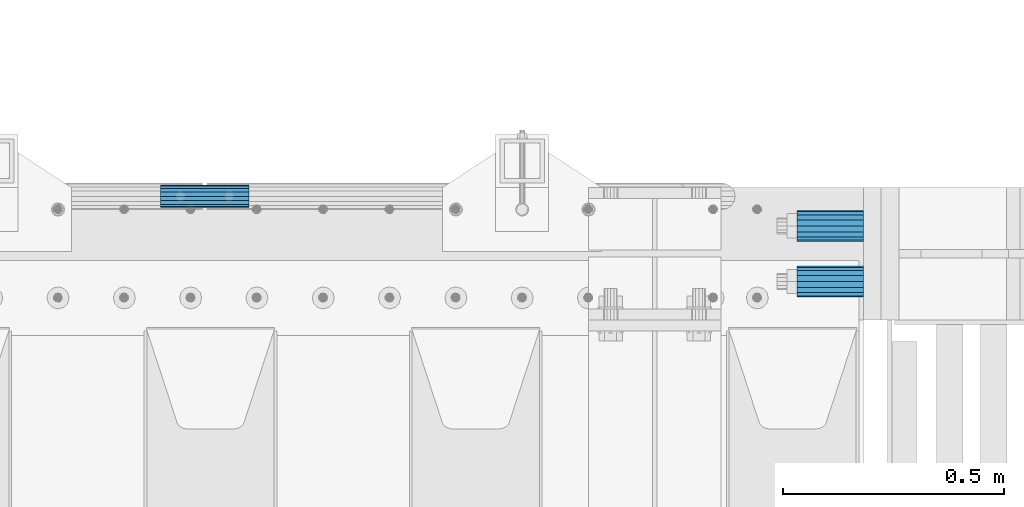
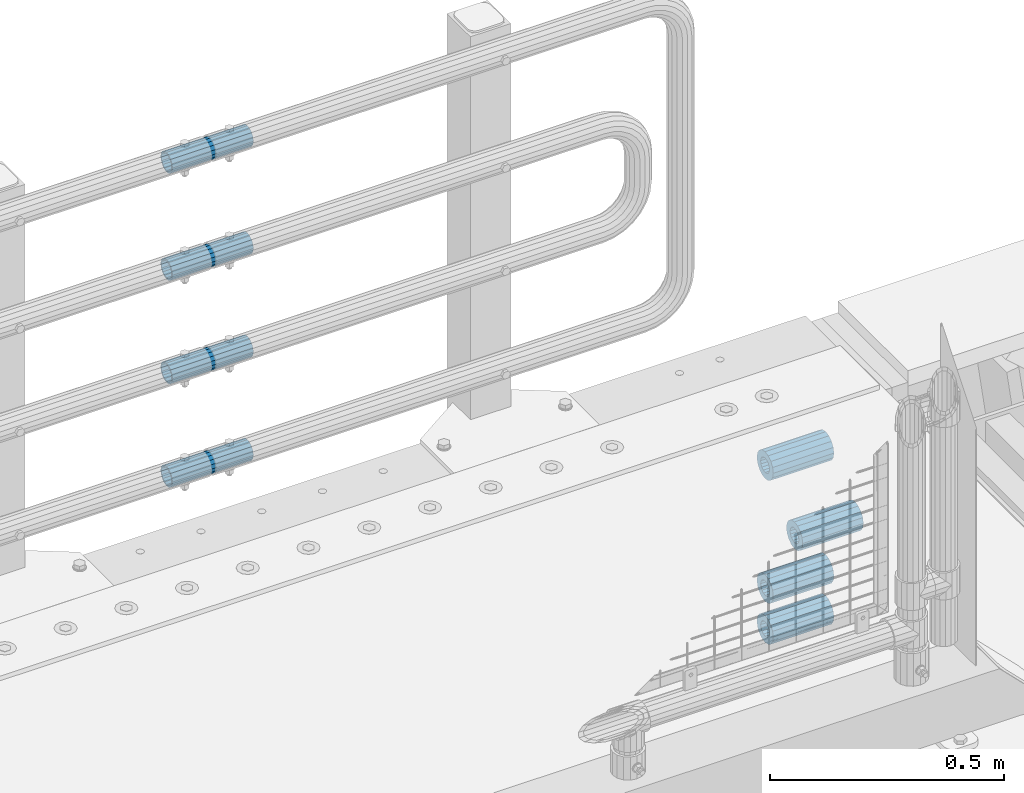
# One storey, part 166 of 240: 8 beams.
"""IFC2X3 building model written with IfcOpenShell, lengths in millimetres."""

from ifc_helpers import new_model, si_unit, frame, origin_with_axes, place, context, subcontext, project, spatial, faceted_brep, material, type_object, element, save


model = new_model("IFC2X3")

# Units and contexts
model_context = context("Model", 3, precision=1e-05, world=origin_with_axes())
body_context = subcontext(model_context, "Body", "Model", "MODEL_VIEW")
ifc_project = project(units=[si_unit("LENGTHUNIT", "METRE", prefix="MILLI"), si_unit("AREAUNIT", "SQUARE_METRE"), si_unit("VOLUMEUNIT", "CUBIC_METRE"), si_unit("MASSUNIT", "GRAM", prefix="KILO"), si_unit("TIMEUNIT", "SECOND"), si_unit("PLANEANGLEUNIT", "RADIAN"), si_unit("SOLIDANGLEUNIT", "STERADIAN"), si_unit("THERMODYNAMICTEMPERATUREUNIT", "DEGREE_CELSIUS"), si_unit("LUMINOUSINTENSITYUNIT", "LUMEN")], contexts=[model_context])

# Site, building, storey
site_placement = place(None, origin_with_axes())
site = spatial("IfcSite", under=ifc_project, at=site_placement, CompositionType="ELEMENT")
building_placement = place(site_placement, origin_with_axes())
building = spatial("IfcBuilding", under=site, at=building_placement, Name="Standard", CompositionType="ELEMENT")
storey_placement = place(building_placement, origin_with_axes())
storey = spatial("IfcBuildingStorey", under=building, at=storey_placement, Name="Undefined", CompositionType="ELEMENT", Elevation=0.0)

# Beams
ifc_material = material()
beam_type_1 = type_object("IfcBeamType", PredefinedType="NOTDEFINED")
beam_1_placement = place(storey_placement, frame((56327.0, 36063.0, -285.0), z_axis=(0.0, 0.0, 1.0), x_axis=(1.0, 0.0, 0.0)))
element("IfcBeam", 1, at=beam_1_placement, inside=storey, type_object=beam_type_1, material=ifc_material, context=body_context, shape_type="Brep", body=[
    faceted_brep([(-1.31236447487026e-07, -18.9999999995492, -6.26459950581193e-09), (0.0, -17.5537111177146, 7.27098521493673), (150.0, -17.5537111177146, 7.27098521493673), (150.0, -19.0, 0.0), (0.0, -13.4350288425449, 13.4350288425444), (150.0, -13.4350288425449, 13.4350288425444), (0.0, -7.27098521493826, 17.5537111177144), (150.0, -7.27098521493826, 17.5537111177144), (-6.35918695479631e-09, 4.50199877377599e-10, 18.9999999937281), (150.0, 0.0, 19.0), (0.0, 7.27098521493826, 17.5537111177144), (150.0, 7.27098521493826, 17.5537111177144), (0.0, 13.4350288425449, 13.4350288425444), (150.0, 13.4350288425449, 13.4350288425444), (0.0, 17.5537111177146, 7.27098521493673), (150.0, 17.5537111177146, 7.27098521493673), (1.33248249767348e-07, 19.0000000004507, -6.26459950581193e-09), (150.0, 19.0, 0.0), (0.0, 17.5537111177146, -7.27098521493673), (150.0, 17.5537111177146, -7.27098521493673), (0.0, 13.4350288425449, -13.4350288425444), (150.0, 13.4350288425449, -13.4350288425444), (0.0, 7.27098521493826, -17.5537111177144), (150.0, 7.27098521493826, -17.5537111177144), (8.37098923511803e-09, 4.50313564215321e-10, -19.0000000062646), (150.0, 0.0, -19.0), (0.0, -7.27098521493826, -17.5537111177144), (150.0, -7.27098521493826, -17.5537111177144), (0.0, -13.4350288425449, -13.4350288425444), (150.0, -13.4350288425449, -13.4350288425444), (0.0, -17.5537111177146, -7.27098521493673), (150.0, -17.5537111177146, -7.27098521493673), (0.0, -35.0, 0.0), (7.27595761418343e-12, -32.335783637895, -13.3939201327739), (150.0, -32.3357836378964, -13.3939201327782), (150.0, -35.0, 0.0), (0.0, -24.7487373415292, -24.7487373415279), (150.0, -24.7487373415279, -24.7487373415292), (7.27595761418343e-12, -13.3939201327781, -32.3357836378891), (150.0, -13.3939201327776, -32.335783637895), (7.27595761418343e-12, 0.0, -35.0), (150.0, 0.0, -35.0), (7.27595761418343e-12, 13.3939201327782, -32.3357836378891), (150.0, 13.3939201327776, -32.335783637895), (0.0, 24.7487373415292, -24.7487373415279), (150.0, 24.7487373415279, -24.7487373415291), (7.27595761418343e-12, 32.335783637895, -13.3939201327739), (150.0, 32.3357836378964, -13.3939201327781), (0.0, 35.0, 0.0), (150.0, 35.0, 0.0), (0.0, 32.335783637895, 13.3939201327812), (150.0, 32.3357836378964, 13.3939201327781), (0.0, 24.7487373415292, 24.7487373415279), (150.0, 24.7487373415279, 24.7487373415292), (0.0, 13.3939201327781, 32.3357836378964), (150.0, 13.3939201327776, 32.335783637895), (0.0, 0.0, 35.0), (150.0, 0.0, 35.0), (0.0, -13.3939201327781, 32.3357836378964), (150.0, -13.3939201327776, 32.335783637895), (0.0, -24.7487373415292, 24.7487373415279), (150.0, -24.7487373415279, 24.7487373415292), (0.0, -32.335783637895, 13.3939201327812), (150.0, -32.3357836378964, 13.3939201327781)], [[[0, 1, 2, 3]], [[1, 4, 5, 2]], [[4, 6, 7, 5]], [[6, 8, 9, 7]], [[8, 10, 11, 9]], [[10, 12, 13, 11]], [[12, 14, 15, 13]], [[14, 16, 17, 15]], [[16, 18, 19, 17]], [[18, 20, 21, 19]], [[20, 22, 23, 21]], [[22, 24, 25, 23]], [[24, 26, 27, 25]], [[26, 28, 29, 27]], [[28, 30, 31, 29]], [[30, 0, 3, 31]], [[32, 33, 34, 35]], [[33, 36, 37, 34]], [[36, 38, 39, 37]], [[38, 40, 41, 39]], [[40, 42, 43, 41]], [[42, 44, 45, 43]], [[44, 46, 47, 45]], [[46, 48, 49, 47]], [[48, 50, 51, 49]], [[50, 52, 53, 51]], [[52, 54, 55, 53]], [[54, 56, 57, 55]], [[56, 58, 59, 57]], [[58, 60, 61, 59]], [[60, 62, 63, 61]], [[62, 32, 35, 63]], [[37, 39, 41, 43, 45, 47, 49, 51, 53, 55, 57, 59, 61, 63, 35, 34], [5, 7, 9, 11, 13, 15, 17, 19, 21, 23, 25, 27, 29, 31, 3, 2]], [[62, 60, 58, 56, 54, 52, 50, 48, 46, 44, 42, 40, 38, 36, 33, 32], [30, 28, 26, 24, 22, 20, 18, 16, 14, 12, 10, 8, 6, 4, 1, 0]]]),
])
beam_2_placement = place(storey_placement, frame((56327.0, 35937.0, -392.0), z_axis=(0.0, 0.0, 1.0), x_axis=(1.0, 0.0, 0.0)))
element("IfcBeam", 2, at=beam_2_placement, inside=storey, type_object=beam_type_1, material=ifc_material, context=body_context, shape_type="Brep", body=[
    faceted_brep([(-1.31236447487026e-07, -18.9999999995492, -6.26459950581193e-09), (0.0, -17.5537111177146, 7.27098521493673), (150.0, -17.5537111177146, 7.27098521493673), (150.0, -19.0, 0.0), (0.0, -13.4350288425449, 13.4350288425444), (150.0, -13.4350288425449, 13.4350288425444), (0.0, -7.27098521493826, 17.5537111177144), (150.0, -7.27098521493826, 17.5537111177144), (-6.35918695479631e-09, 4.50199877377599e-10, 18.9999999937281), (150.0, 0.0, 19.0), (0.0, 7.27098521493826, 17.5537111177144), (150.0, 7.27098521493826, 17.5537111177144), (0.0, 13.4350288425449, 13.4350288425444), (150.0, 13.4350288425449, 13.4350288425444), (0.0, 17.5537111177146, 7.27098521493673), (150.0, 17.5537111177146, 7.27098521493673), (1.33248249767348e-07, 19.0000000004507, -6.26459950581193e-09), (150.0, 19.0, 0.0), (0.0, 17.5537111177146, -7.27098521493673), (150.0, 17.5537111177146, -7.27098521493673), (0.0, 13.4350288425449, -13.4350288425444), (150.0, 13.4350288425449, -13.4350288425444), (0.0, 7.27098521493826, -17.5537111177144), (150.0, 7.27098521493826, -17.5537111177144), (8.37098923511803e-09, 4.50313564215321e-10, -19.0000000062646), (150.0, 0.0, -19.0), (0.0, -7.27098521493826, -17.5537111177144), (150.0, -7.27098521493826, -17.5537111177144), (0.0, -13.4350288425449, -13.4350288425444), (150.0, -13.4350288425449, -13.4350288425444), (0.0, -17.5537111177146, -7.27098521493673), (150.0, -17.5537111177146, -7.27098521493673), (0.0, -35.0, 0.0), (7.27595761418343e-12, -32.335783637895, -13.3939201327739), (150.0, -32.3357836378964, -13.3939201327782), (150.0, -35.0, 0.0), (0.0, -24.7487373415292, -24.7487373415279), (150.0, -24.7487373415279, -24.7487373415292), (7.27595761418343e-12, -13.3939201327781, -32.3357836378891), (150.0, -13.3939201327776, -32.335783637895), (7.27595761418343e-12, 0.0, -35.0), (150.0, 0.0, -35.0), (7.27595761418343e-12, 13.3939201327782, -32.3357836378891), (150.0, 13.3939201327776, -32.335783637895), (0.0, 24.7487373415292, -24.7487373415279), (150.0, 24.7487373415279, -24.7487373415291), (7.27595761418343e-12, 32.335783637895, -13.3939201327739), (150.0, 32.3357836378964, -13.3939201327781), (0.0, 35.0, 0.0), (150.0, 35.0, 0.0), (0.0, 32.335783637895, 13.3939201327812), (150.0, 32.3357836378964, 13.3939201327781), (0.0, 24.7487373415292, 24.7487373415279), (150.0, 24.7487373415279, 24.7487373415292), (0.0, 13.3939201327781, 32.3357836378964), (150.0, 13.3939201327776, 32.335783637895), (0.0, 0.0, 35.0), (150.0, 0.0, 35.0), (0.0, -13.3939201327781, 32.3357836378964), (150.0, -13.3939201327776, 32.335783637895), (0.0, -24.7487373415292, 24.7487373415279), (150.0, -24.7487373415279, 24.7487373415292), (0.0, -32.335783637895, 13.3939201327812), (150.0, -32.3357836378964, 13.3939201327781)], [[[0, 1, 2, 3]], [[1, 4, 5, 2]], [[4, 6, 7, 5]], [[6, 8, 9, 7]], [[8, 10, 11, 9]], [[10, 12, 13, 11]], [[12, 14, 15, 13]], [[14, 16, 17, 15]], [[16, 18, 19, 17]], [[18, 20, 21, 19]], [[20, 22, 23, 21]], [[22, 24, 25, 23]], [[24, 26, 27, 25]], [[26, 28, 29, 27]], [[28, 30, 31, 29]], [[30, 0, 3, 31]], [[32, 33, 34, 35]], [[33, 36, 37, 34]], [[36, 38, 39, 37]], [[38, 40, 41, 39]], [[40, 42, 43, 41]], [[42, 44, 45, 43]], [[44, 46, 47, 45]], [[46, 48, 49, 47]], [[48, 50, 51, 49]], [[50, 52, 53, 51]], [[52, 54, 55, 53]], [[54, 56, 57, 55]], [[56, 58, 59, 57]], [[58, 60, 61, 59]], [[60, 62, 63, 61]], [[62, 32, 35, 63]], [[37, 39, 41, 43, 45, 47, 49, 51, 53, 55, 57, 59, 61, 63, 35, 34], [5, 7, 9, 11, 13, 15, 17, 19, 21, 23, 25, 27, 29, 31, 3, 2]], [[62, 60, 58, 56, 54, 52, 50, 48, 46, 44, 42, 40, 38, 36, 33, 32], [30, 28, 26, 24, 22, 20, 18, 16, 14, 12, 10, 8, 6, 4, 1, 0]]]),
])
beam_3_placement = place(storey_placement, frame((56327.0, 36063.0, -606.0), z_axis=(0.0, 0.0, 1.0), x_axis=(1.0, 0.0, 0.0)))
element("IfcBeam", 3, at=beam_3_placement, inside=storey, type_object=beam_type_1, material=ifc_material, context=body_context, shape_type="Brep", body=[
    faceted_brep([(-1.31236447487026e-07, -18.9999999995492, -6.26459950581193e-09), (0.0, -17.5537111177146, 7.27098521493673), (150.0, -17.5537111177146, 7.27098521493673), (150.0, -19.0, 0.0), (0.0, -13.4350288425449, 13.4350288425444), (150.0, -13.4350288425449, 13.4350288425444), (0.0, -7.27098521493826, 17.5537111177144), (150.0, -7.27098521493826, 17.5537111177144), (-6.35918695479631e-09, 4.50199877377599e-10, 18.9999999937281), (150.0, 0.0, 19.0), (0.0, 7.27098521493826, 17.5537111177144), (150.0, 7.27098521493826, 17.5537111177144), (0.0, 13.4350288425449, 13.4350288425444), (150.0, 13.4350288425449, 13.4350288425444), (0.0, 17.5537111177146, 7.27098521493673), (150.0, 17.5537111177146, 7.27098521493673), (1.33248249767348e-07, 19.0000000004507, -6.26459950581193e-09), (150.0, 19.0, 0.0), (0.0, 17.5537111177146, -7.27098521493673), (150.0, 17.5537111177146, -7.27098521493673), (0.0, 13.4350288425449, -13.4350288425444), (150.0, 13.4350288425449, -13.4350288425444), (0.0, 7.27098521493826, -17.5537111177144), (150.0, 7.27098521493826, -17.5537111177144), (8.37098923511803e-09, 4.50313564215321e-10, -19.0000000062646), (150.0, 0.0, -19.0), (0.0, -7.27098521493826, -17.5537111177144), (150.0, -7.27098521493826, -17.5537111177144), (0.0, -13.4350288425449, -13.4350288425444), (150.0, -13.4350288425449, -13.4350288425444), (0.0, -17.5537111177146, -7.27098521493673), (150.0, -17.5537111177146, -7.27098521493673), (0.0, -35.0, 0.0), (7.27595761418343e-12, -32.335783637895, -13.3939201327739), (150.0, -32.3357836378964, -13.3939201327782), (150.0, -35.0, 0.0), (0.0, -24.7487373415292, -24.7487373415279), (150.0, -24.7487373415279, -24.7487373415292), (7.27595761418343e-12, -13.3939201327781, -32.3357836378891), (150.0, -13.3939201327776, -32.335783637895), (7.27595761418343e-12, 0.0, -35.0), (150.0, 0.0, -35.0), (7.27595761418343e-12, 13.3939201327782, -32.3357836378891), (150.0, 13.3939201327776, -32.335783637895), (0.0, 24.7487373415292, -24.7487373415279), (150.0, 24.7487373415279, -24.7487373415291), (7.27595761418343e-12, 32.335783637895, -13.3939201327739), (150.0, 32.3357836378964, -13.3939201327781), (0.0, 35.0, 0.0), (150.0, 35.0, 0.0), (0.0, 32.335783637895, 13.3939201327812), (150.0, 32.3357836378964, 13.3939201327781), (0.0, 24.7487373415292, 24.7487373415279), (150.0, 24.7487373415279, 24.7487373415292), (0.0, 13.3939201327781, 32.3357836378964), (150.0, 13.3939201327776, 32.335783637895), (0.0, 0.0, 35.0), (150.0, 0.0, 35.0), (0.0, -13.3939201327781, 32.3357836378964), (150.0, -13.3939201327776, 32.335783637895), (0.0, -24.7487373415292, 24.7487373415279), (150.0, -24.7487373415279, 24.7487373415292), (0.0, -32.335783637895, 13.3939201327812), (150.0, -32.3357836378964, 13.3939201327781)], [[[0, 1, 2, 3]], [[1, 4, 5, 2]], [[4, 6, 7, 5]], [[6, 8, 9, 7]], [[8, 10, 11, 9]], [[10, 12, 13, 11]], [[12, 14, 15, 13]], [[14, 16, 17, 15]], [[16, 18, 19, 17]], [[18, 20, 21, 19]], [[20, 22, 23, 21]], [[22, 24, 25, 23]], [[24, 26, 27, 25]], [[26, 28, 29, 27]], [[28, 30, 31, 29]], [[30, 0, 3, 31]], [[32, 33, 34, 35]], [[33, 36, 37, 34]], [[36, 38, 39, 37]], [[38, 40, 41, 39]], [[40, 42, 43, 41]], [[42, 44, 45, 43]], [[44, 46, 47, 45]], [[46, 48, 49, 47]], [[48, 50, 51, 49]], [[50, 52, 53, 51]], [[52, 54, 55, 53]], [[54, 56, 57, 55]], [[56, 58, 59, 57]], [[58, 60, 61, 59]], [[60, 62, 63, 61]], [[62, 32, 35, 63]], [[37, 39, 41, 43, 45, 47, 49, 51, 53, 55, 57, 59, 61, 63, 35, 34], [5, 7, 9, 11, 13, 15, 17, 19, 21, 23, 25, 27, 29, 31, 3, 2]], [[62, 60, 58, 56, 54, 52, 50, 48, 46, 44, 42, 40, 38, 36, 33, 32], [30, 28, 26, 24, 22, 20, 18, 16, 14, 12, 10, 8, 6, 4, 1, 0]]]),
])
beam_4_placement = place(storey_placement, frame((56327.0, 36063.0, -713.0), z_axis=(0.0, 0.0, 1.0), x_axis=(1.0, 0.0, 0.0)))
element("IfcBeam", 4, at=beam_4_placement, inside=storey, type_object=beam_type_1, material=ifc_material, context=body_context, shape_type="Brep", body=[
    faceted_brep([(-1.31236447487026e-07, -18.9999999995492, -6.26459950581193e-09), (0.0, -17.5537111177146, 7.27098521493673), (150.0, -17.5537111177146, 7.27098521493673), (150.0, -19.0, 0.0), (0.0, -13.4350288425449, 13.4350288425444), (150.0, -13.4350288425449, 13.4350288425444), (0.0, -7.27098521493826, 17.5537111177144), (150.0, -7.27098521493826, 17.5537111177144), (-6.35918695479631e-09, 4.50199877377599e-10, 18.9999999937281), (150.0, 0.0, 19.0), (0.0, 7.27098521493826, 17.5537111177144), (150.0, 7.27098521493826, 17.5537111177144), (0.0, 13.4350288425449, 13.4350288425444), (150.0, 13.4350288425449, 13.4350288425444), (0.0, 17.5537111177146, 7.27098521493673), (150.0, 17.5537111177146, 7.27098521493673), (1.33248249767348e-07, 19.0000000004507, -6.26459950581193e-09), (150.0, 19.0, 0.0), (0.0, 17.5537111177146, -7.27098521493673), (150.0, 17.5537111177146, -7.27098521493673), (0.0, 13.4350288425449, -13.4350288425444), (150.0, 13.4350288425449, -13.4350288425444), (0.0, 7.27098521493826, -17.5537111177144), (150.0, 7.27098521493826, -17.5537111177144), (8.37098923511803e-09, 4.50313564215321e-10, -19.0000000062646), (150.0, 0.0, -19.0), (0.0, -7.27098521493826, -17.5537111177144), (150.0, -7.27098521493826, -17.5537111177144), (0.0, -13.4350288425449, -13.4350288425444), (150.0, -13.4350288425449, -13.4350288425444), (0.0, -17.5537111177146, -7.27098521493673), (150.0, -17.5537111177146, -7.27098521493673), (0.0, -35.0, 0.0), (7.27595761418343e-12, -32.335783637895, -13.3939201327739), (150.0, -32.3357836378964, -13.3939201327782), (150.0, -35.0, 0.0), (0.0, -24.7487373415292, -24.7487373415279), (150.0, -24.7487373415279, -24.7487373415292), (7.27595761418343e-12, -13.3939201327781, -32.3357836378891), (150.0, -13.3939201327776, -32.335783637895), (7.27595761418343e-12, 0.0, -35.0), (150.0, 0.0, -35.0), (7.27595761418343e-12, 13.3939201327782, -32.3357836378891), (150.0, 13.3939201327776, -32.335783637895), (0.0, 24.7487373415292, -24.7487373415279), (150.0, 24.7487373415279, -24.7487373415291), (7.27595761418343e-12, 32.335783637895, -13.3939201327739), (150.0, 32.3357836378964, -13.3939201327781), (0.0, 35.0, 0.0), (150.0, 35.0, 0.0), (0.0, 32.335783637895, 13.3939201327812), (150.0, 32.3357836378964, 13.3939201327781), (0.0, 24.7487373415292, 24.7487373415279), (150.0, 24.7487373415279, 24.7487373415292), (0.0, 13.3939201327781, 32.3357836378964), (150.0, 13.3939201327776, 32.335783637895), (0.0, 0.0, 35.0), (150.0, 0.0, 35.0), (0.0, -13.3939201327781, 32.3357836378964), (150.0, -13.3939201327776, 32.335783637895), (0.0, -24.7487373415292, 24.7487373415279), (150.0, -24.7487373415279, 24.7487373415292), (0.0, -32.335783637895, 13.3939201327812), (150.0, -32.3357836378964, 13.3939201327781)], [[[0, 1, 2, 3]], [[1, 4, 5, 2]], [[4, 6, 7, 5]], [[6, 8, 9, 7]], [[8, 10, 11, 9]], [[10, 12, 13, 11]], [[12, 14, 15, 13]], [[14, 16, 17, 15]], [[16, 18, 19, 17]], [[18, 20, 21, 19]], [[20, 22, 23, 21]], [[22, 24, 25, 23]], [[24, 26, 27, 25]], [[26, 28, 29, 27]], [[28, 30, 31, 29]], [[30, 0, 3, 31]], [[32, 33, 34, 35]], [[33, 36, 37, 34]], [[36, 38, 39, 37]], [[38, 40, 41, 39]], [[40, 42, 43, 41]], [[42, 44, 45, 43]], [[44, 46, 47, 45]], [[46, 48, 49, 47]], [[48, 50, 51, 49]], [[50, 52, 53, 51]], [[52, 54, 55, 53]], [[54, 56, 57, 55]], [[56, 58, 59, 57]], [[58, 60, 61, 59]], [[60, 62, 63, 61]], [[62, 32, 35, 63]], [[37, 39, 41, 43, 45, 47, 49, 51, 53, 55, 57, 59, 61, 63, 35, 34], [5, 7, 9, 11, 13, 15, 17, 19, 21, 23, 25, 27, 29, 31, 3, 2]], [[62, 60, 58, 56, 54, 52, 50, 48, 46, 44, 42, 40, 38, 36, 33, 32], [30, 28, 26, 24, 22, 20, 18, 16, 14, 12, 10, 8, 6, 4, 1, 0]]]),
])
beam_type_2 = type_object("IfcBeamType", PredefinedType="NOTDEFINED")
beam_5_placement = place(storey_placement, frame((54886.9975029999, 36129.8500000004, 419.849999999747), z_axis=(0.0, 0.0, 1.0), x_axis=(1.0, 0.0, 0.0)))
element("IfcBeam", 5, at=beam_5_placement, inside=storey, type_object=beam_type_2, material=ifc_material, context=body_context, shape_type="Brep", body=[
    faceted_brep([(0.0, -21.9000000000015, 0.0), (0.0, -20.232961761998, 8.38076716879547), (200.0, -20.232961761998, 8.38076716879547), (200.0, -21.9000000000015, 0.0), (0.0, -15.4856385079838, 15.4856385079854), (200.0, -15.4856385079838, 15.4856385079854), (0.0, -8.38076716879732, 20.2329617619972), (200.0, -8.38076716879732, 20.2329617619972), (0.0, 0.0, 21.9), (200.0, 0.0, 21.9), (0.0, 8.38076716879732, 20.2329617619972), (200.0, 8.38076716879732, 20.2329617619972), (0.0, 15.4856385079838, 15.4856385079854), (200.0, 15.4856385079838, 15.4856385079854), (0.0, 20.232961761998, 8.38076716879547), (200.0, 20.232961761998, 8.38076716879547), (0.0, 21.9000000000015, 0.0), (200.0, 21.9000000000015, 0.0), (0.0, 20.232961761998, -8.38076716879547), (200.0, 20.232961761998, -8.38076716879547), (0.0, 15.4856385079838, -15.4856385079854), (200.0, 15.4856385079838, -15.4856385079854), (0.0, 8.38076716879732, -20.2329617619972), (200.0, 8.38076716879732, -20.2329617619972), (0.0, 0.0, -21.9), (200.0, 0.0, -21.9), (0.0, -8.38076716879732, -20.2329617619972), (200.0, -8.38076716879732, -20.2329617619972), (0.0, -15.4856385079838, -15.4856385079854), (200.0, -15.4856385079838, -15.4856385079854), (0.0, -20.232961761998, -8.38076716879547), (200.0, -20.232961761998, -8.38076716879547), (0.0, -25.5, 0.0), (0.0, -23.5589280790373, -9.7584275253098), (200.0, -23.5589280790373, -9.7584275253098), (200.0, -25.5, 0.0), (0.0, -18.0312229202536, -18.031222920257), (200.0, -18.0312229202536, -18.031222920257), (0.0, -9.75842752531025, -23.5589280790378), (200.0, -9.75842752531025, -23.5589280790378), (0.0, 0.0, -25.5), (200.0, 0.0, -25.5), (0.0, 9.75842752531025, -23.5589280790378), (200.0, 9.75842752531025, -23.5589280790378), (0.0, 18.0312229202536, -18.031222920257), (200.0, 18.0312229202536, -18.031222920257), (0.0, 23.5589280790373, -9.7584275253098), (200.0, 23.5589280790373, -9.7584275253098), (0.0, 25.5, 0.0), (200.0, 25.5, 0.0), (0.0, 23.5589280790373, 9.7584275253098), (200.0, 23.5589280790373, 9.7584275253098), (0.0, 18.0312229202536, 18.031222920257), (200.0, 18.0312229202536, 18.031222920257), (0.0, 9.75842752531025, 23.5589280790378), (200.0, 9.75842752531025, 23.5589280790378), (0.0, 0.0, 25.5), (200.0, 0.0, 25.5), (0.0, -9.75842752531025, 23.5589280790378), (200.0, -9.75842752531025, 23.5589280790378), (0.0, -18.0312229202536, 18.031222920257), (200.0, -18.0312229202536, 18.031222920257), (0.0, -23.5589280790373, 9.7584275253098), (200.0, -23.5589280790373, 9.7584275253098)], [[[0, 1, 2, 3]], [[1, 4, 5, 2]], [[4, 6, 7, 5]], [[6, 8, 9, 7]], [[8, 10, 11, 9]], [[10, 12, 13, 11]], [[12, 14, 15, 13]], [[14, 16, 17, 15]], [[16, 18, 19, 17]], [[18, 20, 21, 19]], [[20, 22, 23, 21]], [[22, 24, 25, 23]], [[24, 26, 27, 25]], [[26, 28, 29, 27]], [[28, 30, 31, 29]], [[30, 0, 3, 31]], [[32, 33, 34, 35]], [[33, 36, 37, 34]], [[36, 38, 39, 37]], [[38, 40, 41, 39]], [[40, 42, 43, 41]], [[42, 44, 45, 43]], [[44, 46, 47, 45]], [[46, 48, 49, 47]], [[48, 50, 51, 49]], [[50, 52, 53, 51]], [[52, 54, 55, 53]], [[54, 56, 57, 55]], [[56, 58, 59, 57]], [[58, 60, 61, 59]], [[60, 62, 63, 61]], [[62, 32, 35, 63]], [[37, 39, 41, 43, 45, 47, 49, 51, 53, 55, 57, 59, 61, 63, 35, 34], [5, 7, 9, 11, 13, 15, 17, 19, 21, 23, 25, 27, 29, 31, 3, 2]], [[62, 60, 58, 56, 54, 52, 50, 48, 46, 44, 42, 40, 38, 36, 33, 32], [30, 28, 26, 24, 22, 20, 18, 16, 14, 12, 10, 8, 6, 4, 1, 0]]]),
])
beam_6_placement = place(storey_placement, frame((54886.9975029999, 36129.8500000004, 149.849999999747), z_axis=(0.0, 0.0, 1.0), x_axis=(1.0, 0.0, 0.0)))
element("IfcBeam", 6, at=beam_6_placement, inside=storey, type_object=beam_type_2, material=ifc_material, context=body_context, shape_type="Brep", body=[
    faceted_brep([(0.0, -21.9000000000015, 0.0), (0.0, -20.232961761998, 8.38076716879547), (200.0, -20.232961761998, 8.38076716879547), (200.0, -21.9000000000015, 0.0), (0.0, -15.4856385079838, 15.4856385079854), (200.0, -15.4856385079838, 15.4856385079854), (0.0, -8.38076716879732, 20.2329617619972), (200.0, -8.38076716879732, 20.2329617619972), (0.0, 0.0, 21.9), (200.0, 0.0, 21.9), (0.0, 8.38076716879732, 20.2329617619972), (200.0, 8.38076716879732, 20.2329617619972), (0.0, 15.4856385079838, 15.4856385079854), (200.0, 15.4856385079838, 15.4856385079854), (0.0, 20.232961761998, 8.38076716879547), (200.0, 20.232961761998, 8.38076716879547), (0.0, 21.9000000000015, 0.0), (200.0, 21.9000000000015, 0.0), (0.0, 20.232961761998, -8.38076716879547), (200.0, 20.232961761998, -8.38076716879547), (0.0, 15.4856385079838, -15.4856385079854), (200.0, 15.4856385079838, -15.4856385079854), (0.0, 8.38076716879732, -20.2329617619972), (200.0, 8.38076716879732, -20.2329617619972), (0.0, 0.0, -21.9), (200.0, 0.0, -21.9), (0.0, -8.38076716879732, -20.2329617619972), (200.0, -8.38076716879732, -20.2329617619972), (0.0, -15.4856385079838, -15.4856385079854), (200.0, -15.4856385079838, -15.4856385079854), (0.0, -20.232961761998, -8.38076716879547), (200.0, -20.232961761998, -8.38076716879547), (0.0, -25.5, 0.0), (0.0, -23.5589280790373, -9.7584275253098), (200.0, -23.5589280790373, -9.7584275253098), (200.0, -25.5, 0.0), (0.0, -18.0312229202536, -18.031222920257), (200.0, -18.0312229202536, -18.031222920257), (0.0, -9.75842752531025, -23.5589280790378), (200.0, -9.75842752531025, -23.5589280790378), (0.0, 0.0, -25.5), (200.0, 0.0, -25.5), (0.0, 9.75842752531025, -23.5589280790378), (200.0, 9.75842752531025, -23.5589280790378), (0.0, 18.0312229202536, -18.031222920257), (200.0, 18.0312229202536, -18.031222920257), (0.0, 23.5589280790373, -9.7584275253098), (200.0, 23.5589280790373, -9.7584275253098), (0.0, 25.5, 0.0), (200.0, 25.5, 0.0), (0.0, 23.5589280790373, 9.7584275253098), (200.0, 23.5589280790373, 9.7584275253098), (0.0, 18.0312229202536, 18.031222920257), (200.0, 18.0312229202536, 18.031222920257), (0.0, 9.75842752531025, 23.5589280790378), (200.0, 9.75842752531025, 23.5589280790378), (0.0, 0.0, 25.5), (200.0, 0.0, 25.5), (0.0, -9.75842752531025, 23.5589280790378), (200.0, -9.75842752531025, 23.5589280790378), (0.0, -18.0312229202536, 18.031222920257), (200.0, -18.0312229202536, 18.031222920257), (0.0, -23.5589280790373, 9.7584275253098), (200.0, -23.5589280790373, 9.7584275253098)], [[[0, 1, 2, 3]], [[1, 4, 5, 2]], [[4, 6, 7, 5]], [[6, 8, 9, 7]], [[8, 10, 11, 9]], [[10, 12, 13, 11]], [[12, 14, 15, 13]], [[14, 16, 17, 15]], [[16, 18, 19, 17]], [[18, 20, 21, 19]], [[20, 22, 23, 21]], [[22, 24, 25, 23]], [[24, 26, 27, 25]], [[26, 28, 29, 27]], [[28, 30, 31, 29]], [[30, 0, 3, 31]], [[32, 33, 34, 35]], [[33, 36, 37, 34]], [[36, 38, 39, 37]], [[38, 40, 41, 39]], [[40, 42, 43, 41]], [[42, 44, 45, 43]], [[44, 46, 47, 45]], [[46, 48, 49, 47]], [[48, 50, 51, 49]], [[50, 52, 53, 51]], [[52, 54, 55, 53]], [[54, 56, 57, 55]], [[56, 58, 59, 57]], [[58, 60, 61, 59]], [[60, 62, 63, 61]], [[62, 32, 35, 63]], [[37, 39, 41, 43, 45, 47, 49, 51, 53, 55, 57, 59, 61, 63, 35, 34], [5, 7, 9, 11, 13, 15, 17, 19, 21, 23, 25, 27, 29, 31, 3, 2]], [[62, 60, 58, 56, 54, 52, 50, 48, 46, 44, 42, 40, 38, 36, 33, 32], [30, 28, 26, 24, 22, 20, 18, 16, 14, 12, 10, 8, 6, 4, 1, 0]]]),
])
beam_7_placement = place(storey_placement, frame((54886.9975029999, 36129.8500000004, 689.849999999747), z_axis=(0.0, 0.0, 1.0), x_axis=(1.0, 0.0, 0.0)))
element("IfcBeam", 7, at=beam_7_placement, inside=storey, type_object=beam_type_2, material=ifc_material, context=body_context, shape_type="Brep", body=[
    faceted_brep([(0.0, -21.9000000000015, 0.0), (0.0, -20.232961761998, 8.38076716879547), (200.0, -20.232961761998, 8.38076716879547), (200.0, -21.9000000000015, 0.0), (0.0, -15.4856385079838, 15.4856385079854), (200.0, -15.4856385079838, 15.4856385079854), (0.0, -8.38076716879732, 20.2329617619972), (200.0, -8.38076716879732, 20.2329617619972), (0.0, 0.0, 21.9), (200.0, 0.0, 21.9), (0.0, 8.38076716879732, 20.2329617619972), (200.0, 8.38076716879732, 20.2329617619972), (0.0, 15.4856385079838, 15.4856385079854), (200.0, 15.4856385079838, 15.4856385079854), (0.0, 20.232961761998, 8.38076716879547), (200.0, 20.232961761998, 8.38076716879547), (0.0, 21.9000000000015, 0.0), (200.0, 21.9000000000015, 0.0), (0.0, 20.232961761998, -8.38076716879547), (200.0, 20.232961761998, -8.38076716879547), (0.0, 15.4856385079838, -15.4856385079854), (200.0, 15.4856385079838, -15.4856385079854), (0.0, 8.38076716879732, -20.2329617619972), (200.0, 8.38076716879732, -20.2329617619972), (0.0, 0.0, -21.9), (200.0, 0.0, -21.9), (0.0, -8.38076716879732, -20.2329617619972), (200.0, -8.38076716879732, -20.2329617619972), (0.0, -15.4856385079838, -15.4856385079854), (200.0, -15.4856385079838, -15.4856385079854), (0.0, -20.232961761998, -8.38076716879547), (200.0, -20.232961761998, -8.38076716879547), (0.0, -25.5, 0.0), (0.0, -23.5589280790373, -9.7584275253098), (200.0, -23.5589280790373, -9.7584275253098), (200.0, -25.5, 0.0), (0.0, -18.0312229202536, -18.031222920257), (200.0, -18.0312229202536, -18.031222920257), (0.0, -9.75842752531025, -23.5589280790378), (200.0, -9.75842752531025, -23.5589280790378), (0.0, 0.0, -25.5), (200.0, 0.0, -25.5), (0.0, 9.75842752531025, -23.5589280790378), (200.0, 9.75842752531025, -23.5589280790378), (0.0, 18.0312229202536, -18.031222920257), (200.0, 18.0312229202536, -18.031222920257), (0.0, 23.5589280790373, -9.7584275253098), (200.0, 23.5589280790373, -9.7584275253098), (0.0, 25.5, 0.0), (200.0, 25.5, 0.0), (0.0, 23.5589280790373, 9.7584275253098), (200.0, 23.5589280790373, 9.7584275253098), (0.0, 18.0312229202536, 18.031222920257), (200.0, 18.0312229202536, 18.031222920257), (0.0, 9.75842752531025, 23.5589280790378), (200.0, 9.75842752531025, 23.5589280790378), (0.0, 0.0, 25.5), (200.0, 0.0, 25.5), (0.0, -9.75842752531025, 23.5589280790378), (200.0, -9.75842752531025, 23.5589280790378), (0.0, -18.0312229202536, 18.031222920257), (200.0, -18.0312229202536, 18.031222920257), (0.0, -23.5589280790373, 9.7584275253098), (200.0, -23.5589280790373, 9.7584275253098)], [[[0, 1, 2, 3]], [[1, 4, 5, 2]], [[4, 6, 7, 5]], [[6, 8, 9, 7]], [[8, 10, 11, 9]], [[10, 12, 13, 11]], [[12, 14, 15, 13]], [[14, 16, 17, 15]], [[16, 18, 19, 17]], [[18, 20, 21, 19]], [[20, 22, 23, 21]], [[22, 24, 25, 23]], [[24, 26, 27, 25]], [[26, 28, 29, 27]], [[28, 30, 31, 29]], [[30, 0, 3, 31]], [[32, 33, 34, 35]], [[33, 36, 37, 34]], [[36, 38, 39, 37]], [[38, 40, 41, 39]], [[40, 42, 43, 41]], [[42, 44, 45, 43]], [[44, 46, 47, 45]], [[46, 48, 49, 47]], [[48, 50, 51, 49]], [[50, 52, 53, 51]], [[52, 54, 55, 53]], [[54, 56, 57, 55]], [[56, 58, 59, 57]], [[58, 60, 61, 59]], [[60, 62, 63, 61]], [[62, 32, 35, 63]], [[37, 39, 41, 43, 45, 47, 49, 51, 53, 55, 57, 59, 61, 63, 35, 34], [5, 7, 9, 11, 13, 15, 17, 19, 21, 23, 25, 27, 29, 31, 3, 2]], [[62, 60, 58, 56, 54, 52, 50, 48, 46, 44, 42, 40, 38, 36, 33, 32], [30, 28, 26, 24, 22, 20, 18, 16, 14, 12, 10, 8, 6, 4, 1, 0]]]),
])
beam_8_placement = place(storey_placement, frame((54886.9975029999, 36129.8500000005, 969.849999999747), z_axis=(0.0, 0.0, 1.0), x_axis=(1.0, 0.0, 0.0)))
element("IfcBeam", 8, at=beam_8_placement, inside=storey, type_object=beam_type_2, material=ifc_material, context=body_context, shape_type="Brep", body=[
    faceted_brep([(0.0, -21.9000000000015, 0.0), (0.0, -20.232961761998, 8.38076716879547), (200.0, -20.232961761998, 8.38076716879547), (200.0, -21.9000000000015, 0.0), (0.0, -15.4856385079838, 15.4856385079854), (200.0, -15.4856385079838, 15.4856385079854), (0.0, -8.38076716879732, 20.2329617619972), (200.0, -8.38076716879732, 20.2329617619972), (0.0, 0.0, 21.9), (200.0, 0.0, 21.9), (0.0, 8.38076716879732, 20.2329617619972), (200.0, 8.38076716879732, 20.2329617619972), (0.0, 15.4856385079838, 15.4856385079854), (200.0, 15.4856385079838, 15.4856385079854), (0.0, 20.232961761998, 8.38076716879547), (200.0, 20.232961761998, 8.38076716879547), (0.0, 21.9000000000015, 0.0), (200.0, 21.9000000000015, 0.0), (0.0, 20.232961761998, -8.38076716879547), (200.0, 20.232961761998, -8.38076716879547), (0.0, 15.4856385079838, -15.4856385079854), (200.0, 15.4856385079838, -15.4856385079854), (0.0, 8.38076716879732, -20.2329617619972), (200.0, 8.38076716879732, -20.2329617619972), (0.0, 0.0, -21.9), (200.0, 0.0, -21.9), (0.0, -8.38076716879732, -20.2329617619972), (200.0, -8.38076716879732, -20.2329617619972), (0.0, -15.4856385079838, -15.4856385079854), (200.0, -15.4856385079838, -15.4856385079854), (0.0, -20.232961761998, -8.38076716879547), (200.0, -20.232961761998, -8.38076716879547), (0.0, -25.5, 0.0), (0.0, -23.5589280790373, -9.7584275253098), (200.0, -23.5589280790373, -9.7584275253098), (200.0, -25.5, 0.0), (0.0, -18.0312229202536, -18.031222920257), (200.0, -18.0312229202536, -18.031222920257), (0.0, -9.75842752531025, -23.5589280790378), (200.0, -9.75842752531025, -23.5589280790378), (0.0, 0.0, -25.5), (200.0, 0.0, -25.5), (0.0, 9.75842752531025, -23.5589280790378), (200.0, 9.75842752531025, -23.5589280790378), (0.0, 18.0312229202536, -18.031222920257), (200.0, 18.0312229202536, -18.031222920257), (0.0, 23.5589280790373, -9.7584275253098), (200.0, 23.5589280790373, -9.7584275253098), (0.0, 25.5, 0.0), (200.0, 25.5, 0.0), (0.0, 23.5589280790373, 9.7584275253098), (200.0, 23.5589280790373, 9.7584275253098), (0.0, 18.0312229202536, 18.031222920257), (200.0, 18.0312229202536, 18.031222920257), (0.0, 9.75842752531025, 23.5589280790378), (200.0, 9.75842752531025, 23.5589280790378), (0.0, 0.0, 25.5), (200.0, 0.0, 25.5), (0.0, -9.75842752531025, 23.5589280790378), (200.0, -9.75842752531025, 23.5589280790378), (0.0, -18.0312229202536, 18.031222920257), (200.0, -18.0312229202536, 18.031222920257), (0.0, -23.5589280790373, 9.7584275253098), (200.0, -23.5589280790373, 9.7584275253098)], [[[0, 1, 2, 3]], [[1, 4, 5, 2]], [[4, 6, 7, 5]], [[6, 8, 9, 7]], [[8, 10, 11, 9]], [[10, 12, 13, 11]], [[12, 14, 15, 13]], [[14, 16, 17, 15]], [[16, 18, 19, 17]], [[18, 20, 21, 19]], [[20, 22, 23, 21]], [[22, 24, 25, 23]], [[24, 26, 27, 25]], [[26, 28, 29, 27]], [[28, 30, 31, 29]], [[30, 0, 3, 31]], [[32, 33, 34, 35]], [[33, 36, 37, 34]], [[36, 38, 39, 37]], [[38, 40, 41, 39]], [[40, 42, 43, 41]], [[42, 44, 45, 43]], [[44, 46, 47, 45]], [[46, 48, 49, 47]], [[48, 50, 51, 49]], [[50, 52, 53, 51]], [[52, 54, 55, 53]], [[54, 56, 57, 55]], [[56, 58, 59, 57]], [[58, 60, 61, 59]], [[60, 62, 63, 61]], [[62, 32, 35, 63]], [[37, 39, 41, 43, 45, 47, 49, 51, 53, 55, 57, 59, 61, 63, 35, 34], [5, 7, 9, 11, 13, 15, 17, 19, 21, 23, 25, 27, 29, 31, 3, 2]], [[62, 60, 58, 56, 54, 52, 50, 48, 46, 44, 42, 40, 38, 36, 33, 32], [30, 28, 26, 24, 22, 20, 18, 16, 14, 12, 10, 8, 6, 4, 1, 0]]]),
])

save(model, "model.ifc")
